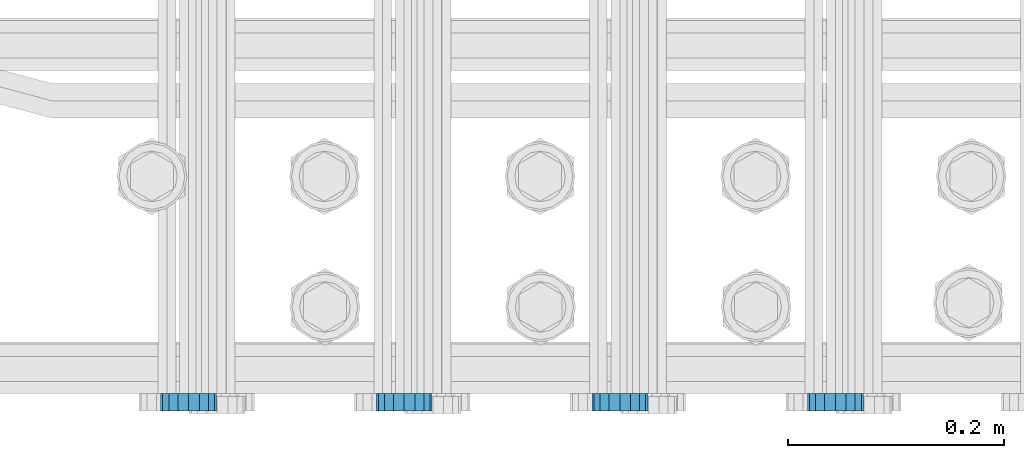
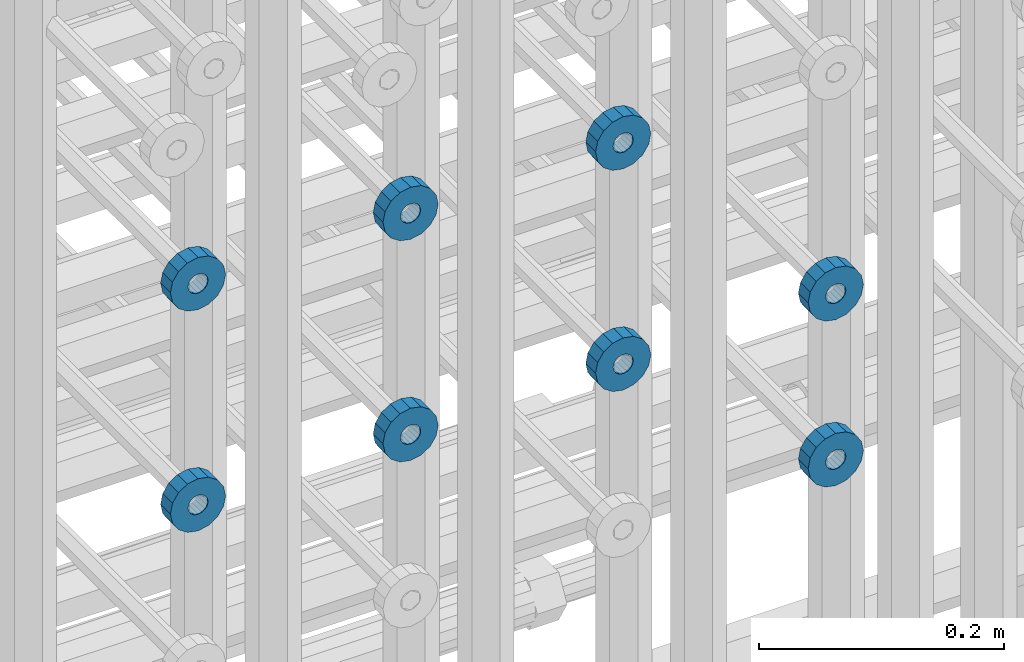
# One storey, part 119 of 177: 8 beams.
"""IFC2X3 building model written with IfcOpenShell, lengths in millimetres."""

from ifc_helpers import new_model, si_unit, frame, origin_with_axes, place, context, subcontext, project, spatial, faceted_brep, material, type_object, element, save


model = new_model("IFC2X3")

# Units and contexts
model_context_1 = context("Model", 3, precision=1e-05, world=origin_with_axes())
model_context_2 = context("Model", 3, precision=1e-05, world=origin_with_axes())
body_context = subcontext(model_context_2, "Body", "Model", "MODEL_VIEW")
ifc_project = project(units=[si_unit("LENGTHUNIT", "METRE", prefix="MILLI"), si_unit("AREAUNIT", "SQUARE_METRE"), si_unit("VOLUMEUNIT", "CUBIC_METRE"), si_unit("MASSUNIT", "GRAM", prefix="KILO"), si_unit("TIMEUNIT", "SECOND"), si_unit("PLANEANGLEUNIT", "RADIAN"), si_unit("SOLIDANGLEUNIT", "STERADIAN"), si_unit("THERMODYNAMICTEMPERATUREUNIT", "DEGREE_CELSIUS"), si_unit("LUMINOUSINTENSITYUNIT", "LUMEN")], contexts=[model_context_1])

# Site, building, storey
site_placement = place(None, origin_with_axes())
site = spatial("IfcSite", under=ifc_project, at=site_placement, CompositionType="ELEMENT")
building_placement = place(site_placement, origin_with_axes())
building = spatial("IfcBuilding", under=site, at=building_placement, Name="Undefined", CompositionType="ELEMENT")
storey_placement = place(building_placement, origin_with_axes())
storey = spatial("IfcBuildingStorey", under=building, at=storey_placement, Name="Undefined", CompositionType="ELEMENT", Elevation=0.0)

# Beams
ifc_material = material(Name="STEEL/Steel_Undefined")
beam_type = type_object("IfcBeamType", PredefinedType="NOTDEFINED")
beam_1_placement = place(storey_placement, frame((2030509.49847313, 6205075.98588034, 20659.9868114202), z_axis=(0.0, 0.0, -1.0), x_axis=(0.0, -1.0, 0.0)))
element("IfcBeam", 1, at=beam_1_placement, inside=storey, type_object=beam_type, material=ifc_material, context=body_context, shape_type="Brep", body=[
    faceted_brep([(0.0, -9.5, 0.0), (0.0, -8.77685555908829, 3.63549260746731), (16.0, -8.77685555908829, 3.63549260746731), (16.0, -9.5, 0.0), (0.0, -6.71751442085952, 6.71751442127061), (16.0, -6.71751442085952, 6.71751442127061), (0.0, -3.63549260701984, 8.77685555885546), (16.0, -3.63549260701984, 8.77685555885546), (-2.02452244836415e-12, 0.0, 9.5), (16.0, 0.0, 9.5), (0.0, 3.63549260701984, 8.77685555885546), (16.0, 3.63549260701984, 8.77685555885546), (0.0, 6.71751442085952, 6.71751442127061), (16.0, 6.71751442085952, 6.71751442127061), (0.0, 8.77685555908829, 3.63549260746731), (16.0, 8.77685555908829, 3.63549260746731), (0.0, 9.5, 0.0), (16.0, 9.5, 0.0), (0.0, 8.77685555908829, -3.63549260746731), (16.0, 8.77685555908829, -3.63549260746731), (0.0, 6.71751442085952, -6.71751442127061), (16.0, 6.71751442085952, -6.71751442127061), (0.0, 3.63549260701984, -8.77685555885546), (16.0, 3.63549260701984, -8.77685555885546), (2.02452244836415e-12, -3.69149155687865e-15, -9.5), (16.0, 0.0, -9.5), (0.0, -3.63549260701984, -8.77685555885546), (16.0, -3.63549260701984, -8.77685555885546), (0.0, -6.71751442085952, -6.71751442127061), (16.0, -6.71751442085952, -6.71751442127061), (0.0, -8.77685555908829, -3.63549260746731), (16.0, -8.77685555908829, -3.63549260746731), (0.0, -26.0, 0.0), (0.0, -24.0208678450435, -9.94976924149159), (16.0, -24.0208678450435, -9.94976924149159), (16.0, -26.0, 0.0), (0.0, -18.3847763109952, -18.3847763108497), (16.0, -18.3847763109952, -18.3847763108497), (0.0, -9.94976924173534, -24.0208678452946), (16.0, -9.94976924173534, -24.0208678452946), (0.0, 0.0, -26.0), (16.0, 0.0, -26.0), (0.0, 9.94976924173534, -24.0208678452946), (16.0, 9.94976924173534, -24.0208678452946), (0.0, 18.3847763109952, -18.3847763108497), (16.0, 18.3847763109952, -18.3847763108497), (0.0, 24.0208678450435, -9.94976924149159), (16.0, 24.0208678450435, -9.94976924149159), (0.0, 26.0, 0.0), (16.0, 26.0, 0.0), (0.0, 24.0208678450435, 9.94976924149159), (16.0, 24.0208678450435, 9.94976924149159), (0.0, 18.3847763109952, 18.3847763108497), (16.0, 18.3847763109952, 18.3847763108497), (0.0, 9.94976924173534, 24.0208678452946), (16.0, 9.94976924173534, 24.0208678452946), (0.0, 0.0, 26.0), (16.0, 0.0, 26.0), (0.0, -9.94976924173534, 24.0208678452946), (16.0, -9.94976924173534, 24.0208678452946), (0.0, -18.3847763109952, 18.3847763108497), (16.0, -18.3847763109952, 18.3847763108497), (0.0, -24.0208678450435, 9.94976924149159), (16.0, -24.0208678450435, 9.94976924149159)], [[[0, 1, 2, 3]], [[1, 4, 5, 2]], [[4, 6, 7, 5]], [[6, 8, 9, 7]], [[8, 10, 11, 9]], [[10, 12, 13, 11]], [[12, 14, 15, 13]], [[14, 16, 17, 15]], [[16, 18, 19, 17]], [[18, 20, 21, 19]], [[20, 22, 23, 21]], [[22, 24, 25, 23]], [[24, 26, 27, 25]], [[26, 28, 29, 27]], [[28, 30, 31, 29]], [[30, 0, 3, 31]], [[32, 33, 34, 35]], [[33, 36, 37, 34]], [[36, 38, 39, 37]], [[38, 40, 41, 39]], [[40, 42, 43, 41]], [[42, 44, 45, 43]], [[44, 46, 47, 45]], [[46, 48, 49, 47]], [[48, 50, 51, 49]], [[50, 52, 53, 51]], [[52, 54, 55, 53]], [[54, 56, 57, 55]], [[56, 58, 59, 57]], [[58, 60, 61, 59]], [[60, 62, 63, 61]], [[62, 32, 35, 63]], [[37, 39, 41, 43, 45, 47, 49, 51, 53, 55, 57, 59, 61, 63, 35, 34], [5, 7, 9, 11, 13, 15, 17, 19, 21, 23, 25, 27, 29, 31, 3, 2]], [[62, 60, 58, 56, 54, 52, 50, 48, 46, 44, 42, 40, 38, 36, 33, 32], [30, 28, 26, 24, 22, 20, 18, 16, 14, 12, 10, 8, 6, 4, 1, 0]]]),
])
beam_2_placement = place(storey_placement, frame((2030309.49847313, 6205075.98588034, 20659.9868114202), z_axis=(0.0, 0.0, -1.0), x_axis=(0.0, -1.0, 0.0)))
element("IfcBeam", 2, at=beam_2_placement, inside=storey, type_object=beam_type, material=ifc_material, context=body_context, shape_type="Brep", body=[
    faceted_brep([(0.0, -9.5, 0.0), (0.0, -8.77685555908829, 3.63549260746731), (16.0, -8.77685555908829, 3.63549260746731), (16.0, -9.5, 0.0), (0.0, -6.71751442085952, 6.71751442127061), (16.0, -6.71751442085952, 6.71751442127061), (0.0, -3.63549260701984, 8.77685555885546), (16.0, -3.63549260701984, 8.77685555885546), (-2.02452244836415e-12, 0.0, 9.5), (16.0, 0.0, 9.5), (0.0, 3.63549260701984, 8.77685555885546), (16.0, 3.63549260701984, 8.77685555885546), (0.0, 6.71751442085952, 6.71751442127061), (16.0, 6.71751442085952, 6.71751442127061), (0.0, 8.77685555908829, 3.63549260746731), (16.0, 8.77685555908829, 3.63549260746731), (0.0, 9.5, 0.0), (16.0, 9.5, 0.0), (0.0, 8.77685555908829, -3.63549260746731), (16.0, 8.77685555908829, -3.63549260746731), (0.0, 6.71751442085952, -6.71751442127061), (16.0, 6.71751442085952, -6.71751442127061), (0.0, 3.63549260701984, -8.77685555885546), (16.0, 3.63549260701984, -8.77685555885546), (2.02452244836415e-12, -3.69149155687865e-15, -9.5), (16.0, 0.0, -9.5), (0.0, -3.63549260701984, -8.77685555885546), (16.0, -3.63549260701984, -8.77685555885546), (0.0, -6.71751442085952, -6.71751442127061), (16.0, -6.71751442085952, -6.71751442127061), (0.0, -8.77685555908829, -3.63549260746731), (16.0, -8.77685555908829, -3.63549260746731), (0.0, -26.0, 0.0), (0.0, -24.0208678450435, -9.94976924149159), (16.0, -24.0208678450435, -9.94976924149159), (16.0, -26.0, 0.0), (0.0, -18.3847763109952, -18.3847763108497), (16.0, -18.3847763109952, -18.3847763108497), (0.0, -9.94976924173534, -24.0208678452946), (16.0, -9.94976924173534, -24.0208678452946), (0.0, 0.0, -26.0), (16.0, 0.0, -26.0), (0.0, 9.94976924173534, -24.0208678452946), (16.0, 9.94976924173534, -24.0208678452946), (0.0, 18.3847763109952, -18.3847763108497), (16.0, 18.3847763109952, -18.3847763108497), (0.0, 24.0208678450435, -9.94976924149159), (16.0, 24.0208678450435, -9.94976924149159), (0.0, 26.0, 0.0), (16.0, 26.0, 0.0), (0.0, 24.0208678450435, 9.94976924149159), (16.0, 24.0208678450435, 9.94976924149159), (0.0, 18.3847763109952, 18.3847763108497), (16.0, 18.3847763109952, 18.3847763108497), (0.0, 9.94976924173534, 24.0208678452946), (16.0, 9.94976924173534, 24.0208678452946), (0.0, 0.0, 26.0), (16.0, 0.0, 26.0), (0.0, -9.94976924173534, 24.0208678452946), (16.0, -9.94976924173534, 24.0208678452946), (0.0, -18.3847763109952, 18.3847763108497), (16.0, -18.3847763109952, 18.3847763108497), (0.0, -24.0208678450435, 9.94976924149159), (16.0, -24.0208678450435, 9.94976924149159)], [[[0, 1, 2, 3]], [[1, 4, 5, 2]], [[4, 6, 7, 5]], [[6, 8, 9, 7]], [[8, 10, 11, 9]], [[10, 12, 13, 11]], [[12, 14, 15, 13]], [[14, 16, 17, 15]], [[16, 18, 19, 17]], [[18, 20, 21, 19]], [[20, 22, 23, 21]], [[22, 24, 25, 23]], [[24, 26, 27, 25]], [[26, 28, 29, 27]], [[28, 30, 31, 29]], [[30, 0, 3, 31]], [[32, 33, 34, 35]], [[33, 36, 37, 34]], [[36, 38, 39, 37]], [[38, 40, 41, 39]], [[40, 42, 43, 41]], [[42, 44, 45, 43]], [[44, 46, 47, 45]], [[46, 48, 49, 47]], [[48, 50, 51, 49]], [[50, 52, 53, 51]], [[52, 54, 55, 53]], [[54, 56, 57, 55]], [[56, 58, 59, 57]], [[58, 60, 61, 59]], [[60, 62, 63, 61]], [[62, 32, 35, 63]], [[37, 39, 41, 43, 45, 47, 49, 51, 53, 55, 57, 59, 61, 63, 35, 34], [5, 7, 9, 11, 13, 15, 17, 19, 21, 23, 25, 27, 29, 31, 3, 2]], [[62, 60, 58, 56, 54, 52, 50, 48, 46, 44, 42, 40, 38, 36, 33, 32], [30, 28, 26, 24, 22, 20, 18, 16, 14, 12, 10, 8, 6, 4, 1, 0]]]),
])
beam_3_placement = place(storey_placement, frame((2030109.49847313, 6205075.98588034, 20659.9868114202), z_axis=(0.0, 0.0, -1.0), x_axis=(0.0, -1.0, 0.0)))
element("IfcBeam", 3, at=beam_3_placement, inside=storey, type_object=beam_type, material=ifc_material, context=body_context, shape_type="Brep", body=[
    faceted_brep([(0.0, -9.5, 0.0), (0.0, -8.77685555908829, 3.63549260746731), (16.0, -8.77685555908829, 3.63549260746731), (16.0, -9.5, 0.0), (0.0, -6.71751442085952, 6.71751442127061), (16.0, -6.71751442085952, 6.71751442127061), (0.0, -3.63549260701984, 8.77685555885546), (16.0, -3.63549260701984, 8.77685555885546), (-2.02452244836415e-12, 0.0, 9.5), (16.0, 0.0, 9.5), (0.0, 3.63549260701984, 8.77685555885546), (16.0, 3.63549260701984, 8.77685555885546), (0.0, 6.71751442085952, 6.71751442127061), (16.0, 6.71751442085952, 6.71751442127061), (0.0, 8.77685555908829, 3.63549260746731), (16.0, 8.77685555908829, 3.63549260746731), (0.0, 9.5, 0.0), (16.0, 9.5, 0.0), (0.0, 8.77685555908829, -3.63549260746731), (16.0, 8.77685555908829, -3.63549260746731), (0.0, 6.71751442085952, -6.71751442127061), (16.0, 6.71751442085952, -6.71751442127061), (0.0, 3.63549260701984, -8.77685555885546), (16.0, 3.63549260701984, -8.77685555885546), (2.02452244836415e-12, -3.69149155687865e-15, -9.5), (16.0, 0.0, -9.5), (0.0, -3.63549260701984, -8.77685555885546), (16.0, -3.63549260701984, -8.77685555885546), (0.0, -6.71751442085952, -6.71751442127061), (16.0, -6.71751442085952, -6.71751442127061), (0.0, -8.77685555908829, -3.63549260746731), (16.0, -8.77685555908829, -3.63549260746731), (0.0, -26.0, 0.0), (0.0, -24.0208678450435, -9.94976924149159), (16.0, -24.0208678450435, -9.94976924149159), (16.0, -26.0, 0.0), (0.0, -18.3847763109952, -18.3847763108497), (16.0, -18.3847763109952, -18.3847763108497), (0.0, -9.94976924173534, -24.0208678452946), (16.0, -9.94976924173534, -24.0208678452946), (0.0, 0.0, -26.0), (16.0, 0.0, -26.0), (0.0, 9.94976924173534, -24.0208678452946), (16.0, 9.94976924173534, -24.0208678452946), (0.0, 18.3847763109952, -18.3847763108497), (16.0, 18.3847763109952, -18.3847763108497), (0.0, 24.0208678450435, -9.94976924149159), (16.0, 24.0208678450435, -9.94976924149159), (0.0, 26.0, 0.0), (16.0, 26.0, 0.0), (0.0, 24.0208678450435, 9.94976924149159), (16.0, 24.0208678450435, 9.94976924149159), (0.0, 18.3847763109952, 18.3847763108497), (16.0, 18.3847763109952, 18.3847763108497), (0.0, 9.94976924173534, 24.0208678452946), (16.0, 9.94976924173534, 24.0208678452946), (0.0, 0.0, 26.0), (16.0, 0.0, 26.0), (0.0, -9.94976924173534, 24.0208678452946), (16.0, -9.94976924173534, 24.0208678452946), (0.0, -18.3847763109952, 18.3847763108497), (16.0, -18.3847763109952, 18.3847763108497), (0.0, -24.0208678450435, 9.94976924149159), (16.0, -24.0208678450435, 9.94976924149159)], [[[0, 1, 2, 3]], [[1, 4, 5, 2]], [[4, 6, 7, 5]], [[6, 8, 9, 7]], [[8, 10, 11, 9]], [[10, 12, 13, 11]], [[12, 14, 15, 13]], [[14, 16, 17, 15]], [[16, 18, 19, 17]], [[18, 20, 21, 19]], [[20, 22, 23, 21]], [[22, 24, 25, 23]], [[24, 26, 27, 25]], [[26, 28, 29, 27]], [[28, 30, 31, 29]], [[30, 0, 3, 31]], [[32, 33, 34, 35]], [[33, 36, 37, 34]], [[36, 38, 39, 37]], [[38, 40, 41, 39]], [[40, 42, 43, 41]], [[42, 44, 45, 43]], [[44, 46, 47, 45]], [[46, 48, 49, 47]], [[48, 50, 51, 49]], [[50, 52, 53, 51]], [[52, 54, 55, 53]], [[54, 56, 57, 55]], [[56, 58, 59, 57]], [[58, 60, 61, 59]], [[60, 62, 63, 61]], [[62, 32, 35, 63]], [[37, 39, 41, 43, 45, 47, 49, 51, 53, 55, 57, 59, 61, 63, 35, 34], [5, 7, 9, 11, 13, 15, 17, 19, 21, 23, 25, 27, 29, 31, 3, 2]], [[62, 60, 58, 56, 54, 52, 50, 48, 46, 44, 42, 40, 38, 36, 33, 32], [30, 28, 26, 24, 22, 20, 18, 16, 14, 12, 10, 8, 6, 4, 1, 0]]]),
])
beam_4_placement = place(storey_placement, frame((2030709.49847313, 6205075.98588033, 20439.9868114202), z_axis=(0.0, 0.0, -1.0), x_axis=(0.0, -1.0, 0.0)))
element("IfcBeam", 4, at=beam_4_placement, inside=storey, type_object=beam_type, material=ifc_material, context=body_context, shape_type="Brep", body=[
    faceted_brep([(0.0, -9.5, 0.0), (0.0, -8.77685555908829, 3.63549260746731), (16.0, -8.77685555908829, 3.63549260746731), (16.0, -9.5, 0.0), (0.0, -6.71751442085952, 6.71751442127061), (16.0, -6.71751442085952, 6.71751442127061), (0.0, -3.63549260701984, 8.77685555885546), (16.0, -3.63549260701984, 8.77685555885546), (-2.02452244836415e-12, 0.0, 9.5), (16.0, 0.0, 9.5), (0.0, 3.63549260701984, 8.77685555885546), (16.0, 3.63549260701984, 8.77685555885546), (0.0, 6.71751442085952, 6.71751442127061), (16.0, 6.71751442085952, 6.71751442127061), (0.0, 8.77685555908829, 3.63549260746731), (16.0, 8.77685555908829, 3.63549260746731), (0.0, 9.5, 0.0), (16.0, 9.5, 0.0), (0.0, 8.77685555908829, -3.63549260746731), (16.0, 8.77685555908829, -3.63549260746731), (0.0, 6.71751442085952, -6.71751442127061), (16.0, 6.71751442085952, -6.71751442127061), (0.0, 3.63549260701984, -8.77685555885546), (16.0, 3.63549260701984, -8.77685555885546), (2.02452244836415e-12, -3.69149155687865e-15, -9.5), (16.0, 0.0, -9.5), (0.0, -3.63549260701984, -8.77685555885546), (16.0, -3.63549260701984, -8.77685555885546), (0.0, -6.71751442085952, -6.71751442127061), (16.0, -6.71751442085952, -6.71751442127061), (0.0, -8.77685555908829, -3.63549260746731), (16.0, -8.77685555908829, -3.63549260746731), (0.0, -26.0, 0.0), (0.0, -24.0208678450435, -9.94976924149159), (16.0, -24.0208678450435, -9.94976924149159), (16.0, -26.0, 0.0), (0.0, -18.3847763109952, -18.3847763108497), (16.0, -18.3847763109952, -18.3847763108497), (0.0, -9.94976924173534, -24.0208678452946), (16.0, -9.94976924173534, -24.0208678452946), (0.0, 0.0, -26.0), (16.0, 0.0, -26.0), (0.0, 9.94976924173534, -24.0208678452946), (16.0, 9.94976924173534, -24.0208678452946), (0.0, 18.3847763109952, -18.3847763108497), (16.0, 18.3847763109952, -18.3847763108497), (0.0, 24.0208678450435, -9.94976924149159), (16.0, 24.0208678450435, -9.94976924149159), (0.0, 26.0, 0.0), (16.0, 26.0, 0.0), (0.0, 24.0208678450435, 9.94976924149159), (16.0, 24.0208678450435, 9.94976924149159), (0.0, 18.3847763109952, 18.3847763108497), (16.0, 18.3847763109952, 18.3847763108497), (0.0, 9.94976924173534, 24.0208678452946), (16.0, 9.94976924173534, 24.0208678452946), (0.0, 0.0, 26.0), (16.0, 0.0, 26.0), (0.0, -9.94976924173534, 24.0208678452946), (16.0, -9.94976924173534, 24.0208678452946), (0.0, -18.3847763109952, 18.3847763108497), (16.0, -18.3847763109952, 18.3847763108497), (0.0, -24.0208678450435, 9.94976924149159), (16.0, -24.0208678450435, 9.94976924149159)], [[[0, 1, 2, 3]], [[1, 4, 5, 2]], [[4, 6, 7, 5]], [[6, 8, 9, 7]], [[8, 10, 11, 9]], [[10, 12, 13, 11]], [[12, 14, 15, 13]], [[14, 16, 17, 15]], [[16, 18, 19, 17]], [[18, 20, 21, 19]], [[20, 22, 23, 21]], [[22, 24, 25, 23]], [[24, 26, 27, 25]], [[26, 28, 29, 27]], [[28, 30, 31, 29]], [[30, 0, 3, 31]], [[32, 33, 34, 35]], [[33, 36, 37, 34]], [[36, 38, 39, 37]], [[38, 40, 41, 39]], [[40, 42, 43, 41]], [[42, 44, 45, 43]], [[44, 46, 47, 45]], [[46, 48, 49, 47]], [[48, 50, 51, 49]], [[50, 52, 53, 51]], [[52, 54, 55, 53]], [[54, 56, 57, 55]], [[56, 58, 59, 57]], [[58, 60, 61, 59]], [[60, 62, 63, 61]], [[62, 32, 35, 63]], [[37, 39, 41, 43, 45, 47, 49, 51, 53, 55, 57, 59, 61, 63, 35, 34], [5, 7, 9, 11, 13, 15, 17, 19, 21, 23, 25, 27, 29, 31, 3, 2]], [[62, 60, 58, 56, 54, 52, 50, 48, 46, 44, 42, 40, 38, 36, 33, 32], [30, 28, 26, 24, 22, 20, 18, 16, 14, 12, 10, 8, 6, 4, 1, 0]]]),
])
beam_5_placement = place(storey_placement, frame((2030509.49847313, 6205075.98588033, 20439.9868114202), z_axis=(0.0, 0.0, -1.0), x_axis=(0.0, -1.0, 0.0)))
element("IfcBeam", 5, at=beam_5_placement, inside=storey, type_object=beam_type, material=ifc_material, context=body_context, shape_type="Brep", body=[
    faceted_brep([(0.0, -9.5, 0.0), (0.0, -8.77685555908829, 3.63549260746731), (16.0, -8.77685555908829, 3.63549260746731), (16.0, -9.5, 0.0), (0.0, -6.71751442085952, 6.71751442127061), (16.0, -6.71751442085952, 6.71751442127061), (0.0, -3.63549260701984, 8.77685555885546), (16.0, -3.63549260701984, 8.77685555885546), (-2.02452244836415e-12, 0.0, 9.5), (16.0, 0.0, 9.5), (0.0, 3.63549260701984, 8.77685555885546), (16.0, 3.63549260701984, 8.77685555885546), (0.0, 6.71751442085952, 6.71751442127061), (16.0, 6.71751442085952, 6.71751442127061), (0.0, 8.77685555908829, 3.63549260746731), (16.0, 8.77685555908829, 3.63549260746731), (0.0, 9.5, 0.0), (16.0, 9.5, 0.0), (0.0, 8.77685555908829, -3.63549260746731), (16.0, 8.77685555908829, -3.63549260746731), (0.0, 6.71751442085952, -6.71751442127061), (16.0, 6.71751442085952, -6.71751442127061), (0.0, 3.63549260701984, -8.77685555885546), (16.0, 3.63549260701984, -8.77685555885546), (2.02452244836415e-12, -3.69149155687865e-15, -9.5), (16.0, 0.0, -9.5), (0.0, -3.63549260701984, -8.77685555885546), (16.0, -3.63549260701984, -8.77685555885546), (0.0, -6.71751442085952, -6.71751442127061), (16.0, -6.71751442085952, -6.71751442127061), (0.0, -8.77685555908829, -3.63549260746731), (16.0, -8.77685555908829, -3.63549260746731), (0.0, -26.0, 0.0), (0.0, -24.0208678450435, -9.94976924149159), (16.0, -24.0208678450435, -9.94976924149159), (16.0, -26.0, 0.0), (0.0, -18.3847763109952, -18.3847763108497), (16.0, -18.3847763109952, -18.3847763108497), (0.0, -9.94976924173534, -24.0208678452946), (16.0, -9.94976924173534, -24.0208678452946), (0.0, 0.0, -26.0), (16.0, 0.0, -26.0), (0.0, 9.94976924173534, -24.0208678452946), (16.0, 9.94976924173534, -24.0208678452946), (0.0, 18.3847763109952, -18.3847763108497), (16.0, 18.3847763109952, -18.3847763108497), (0.0, 24.0208678450435, -9.94976924149159), (16.0, 24.0208678450435, -9.94976924149159), (0.0, 26.0, 0.0), (16.0, 26.0, 0.0), (0.0, 24.0208678450435, 9.94976924149159), (16.0, 24.0208678450435, 9.94976924149159), (0.0, 18.3847763109952, 18.3847763108497), (16.0, 18.3847763109952, 18.3847763108497), (0.0, 9.94976924173534, 24.0208678452946), (16.0, 9.94976924173534, 24.0208678452946), (0.0, 0.0, 26.0), (16.0, 0.0, 26.0), (0.0, -9.94976924173534, 24.0208678452946), (16.0, -9.94976924173534, 24.0208678452946), (0.0, -18.3847763109952, 18.3847763108497), (16.0, -18.3847763109952, 18.3847763108497), (0.0, -24.0208678450435, 9.94976924149159), (16.0, -24.0208678450435, 9.94976924149159)], [[[0, 1, 2, 3]], [[1, 4, 5, 2]], [[4, 6, 7, 5]], [[6, 8, 9, 7]], [[8, 10, 11, 9]], [[10, 12, 13, 11]], [[12, 14, 15, 13]], [[14, 16, 17, 15]], [[16, 18, 19, 17]], [[18, 20, 21, 19]], [[20, 22, 23, 21]], [[22, 24, 25, 23]], [[24, 26, 27, 25]], [[26, 28, 29, 27]], [[28, 30, 31, 29]], [[30, 0, 3, 31]], [[32, 33, 34, 35]], [[33, 36, 37, 34]], [[36, 38, 39, 37]], [[38, 40, 41, 39]], [[40, 42, 43, 41]], [[42, 44, 45, 43]], [[44, 46, 47, 45]], [[46, 48, 49, 47]], [[48, 50, 51, 49]], [[50, 52, 53, 51]], [[52, 54, 55, 53]], [[54, 56, 57, 55]], [[56, 58, 59, 57]], [[58, 60, 61, 59]], [[60, 62, 63, 61]], [[62, 32, 35, 63]], [[37, 39, 41, 43, 45, 47, 49, 51, 53, 55, 57, 59, 61, 63, 35, 34], [5, 7, 9, 11, 13, 15, 17, 19, 21, 23, 25, 27, 29, 31, 3, 2]], [[62, 60, 58, 56, 54, 52, 50, 48, 46, 44, 42, 40, 38, 36, 33, 32], [30, 28, 26, 24, 22, 20, 18, 16, 14, 12, 10, 8, 6, 4, 1, 0]]]),
])
beam_6_placement = place(storey_placement, frame((2030309.49847313, 6205075.98588033, 20439.9868114202), z_axis=(0.0, 0.0, -1.0), x_axis=(0.0, -1.0, 0.0)))
element("IfcBeam", 6, at=beam_6_placement, inside=storey, type_object=beam_type, material=ifc_material, context=body_context, shape_type="Brep", body=[
    faceted_brep([(0.0, -9.5, 0.0), (0.0, -8.77685555908829, 3.63549260746731), (16.0, -8.77685555908829, 3.63549260746731), (16.0, -9.5, 0.0), (0.0, -6.71751442085952, 6.71751442127061), (16.0, -6.71751442085952, 6.71751442127061), (0.0, -3.63549260701984, 8.77685555885546), (16.0, -3.63549260701984, 8.77685555885546), (-2.02452244836415e-12, 0.0, 9.5), (16.0, 0.0, 9.5), (0.0, 3.63549260701984, 8.77685555885546), (16.0, 3.63549260701984, 8.77685555885546), (0.0, 6.71751442085952, 6.71751442127061), (16.0, 6.71751442085952, 6.71751442127061), (0.0, 8.77685555908829, 3.63549260746731), (16.0, 8.77685555908829, 3.63549260746731), (0.0, 9.5, 0.0), (16.0, 9.5, 0.0), (0.0, 8.77685555908829, -3.63549260746731), (16.0, 8.77685555908829, -3.63549260746731), (0.0, 6.71751442085952, -6.71751442127061), (16.0, 6.71751442085952, -6.71751442127061), (0.0, 3.63549260701984, -8.77685555885546), (16.0, 3.63549260701984, -8.77685555885546), (2.02452244836415e-12, -3.69149155687865e-15, -9.5), (16.0, 0.0, -9.5), (0.0, -3.63549260701984, -8.77685555885546), (16.0, -3.63549260701984, -8.77685555885546), (0.0, -6.71751442085952, -6.71751442127061), (16.0, -6.71751442085952, -6.71751442127061), (0.0, -8.77685555908829, -3.63549260746731), (16.0, -8.77685555908829, -3.63549260746731), (0.0, -26.0, 0.0), (0.0, -24.0208678450435, -9.94976924149159), (16.0, -24.0208678450435, -9.94976924149159), (16.0, -26.0, 0.0), (0.0, -18.3847763109952, -18.3847763108497), (16.0, -18.3847763109952, -18.3847763108497), (0.0, -9.94976924173534, -24.0208678452946), (16.0, -9.94976924173534, -24.0208678452946), (0.0, 0.0, -26.0), (16.0, 0.0, -26.0), (0.0, 9.94976924173534, -24.0208678452946), (16.0, 9.94976924173534, -24.0208678452946), (0.0, 18.3847763109952, -18.3847763108497), (16.0, 18.3847763109952, -18.3847763108497), (0.0, 24.0208678450435, -9.94976924149159), (16.0, 24.0208678450435, -9.94976924149159), (0.0, 26.0, 0.0), (16.0, 26.0, 0.0), (0.0, 24.0208678450435, 9.94976924149159), (16.0, 24.0208678450435, 9.94976924149159), (0.0, 18.3847763109952, 18.3847763108497), (16.0, 18.3847763109952, 18.3847763108497), (0.0, 9.94976924173534, 24.0208678452946), (16.0, 9.94976924173534, 24.0208678452946), (0.0, 0.0, 26.0), (16.0, 0.0, 26.0), (0.0, -9.94976924173534, 24.0208678452946), (16.0, -9.94976924173534, 24.0208678452946), (0.0, -18.3847763109952, 18.3847763108497), (16.0, -18.3847763109952, 18.3847763108497), (0.0, -24.0208678450435, 9.94976924149159), (16.0, -24.0208678450435, 9.94976924149159)], [[[0, 1, 2, 3]], [[1, 4, 5, 2]], [[4, 6, 7, 5]], [[6, 8, 9, 7]], [[8, 10, 11, 9]], [[10, 12, 13, 11]], [[12, 14, 15, 13]], [[14, 16, 17, 15]], [[16, 18, 19, 17]], [[18, 20, 21, 19]], [[20, 22, 23, 21]], [[22, 24, 25, 23]], [[24, 26, 27, 25]], [[26, 28, 29, 27]], [[28, 30, 31, 29]], [[30, 0, 3, 31]], [[32, 33, 34, 35]], [[33, 36, 37, 34]], [[36, 38, 39, 37]], [[38, 40, 41, 39]], [[40, 42, 43, 41]], [[42, 44, 45, 43]], [[44, 46, 47, 45]], [[46, 48, 49, 47]], [[48, 50, 51, 49]], [[50, 52, 53, 51]], [[52, 54, 55, 53]], [[54, 56, 57, 55]], [[56, 58, 59, 57]], [[58, 60, 61, 59]], [[60, 62, 63, 61]], [[62, 32, 35, 63]], [[37, 39, 41, 43, 45, 47, 49, 51, 53, 55, 57, 59, 61, 63, 35, 34], [5, 7, 9, 11, 13, 15, 17, 19, 21, 23, 25, 27, 29, 31, 3, 2]], [[62, 60, 58, 56, 54, 52, 50, 48, 46, 44, 42, 40, 38, 36, 33, 32], [30, 28, 26, 24, 22, 20, 18, 16, 14, 12, 10, 8, 6, 4, 1, 0]]]),
])
beam_7_placement = place(storey_placement, frame((2030109.49847313, 6205075.98588033, 20439.9868114202), z_axis=(0.0, 0.0, -1.0), x_axis=(0.0, -1.0, 0.0)))
element("IfcBeam", 7, at=beam_7_placement, inside=storey, type_object=beam_type, material=ifc_material, context=body_context, shape_type="Brep", body=[
    faceted_brep([(0.0, -9.5, 0.0), (0.0, -8.77685555908829, 3.63549260746731), (16.0, -8.77685555908829, 3.63549260746731), (16.0, -9.5, 0.0), (0.0, -6.71751442085952, 6.71751442127061), (16.0, -6.71751442085952, 6.71751442127061), (0.0, -3.63549260701984, 8.77685555885546), (16.0, -3.63549260701984, 8.77685555885546), (-2.02452244836415e-12, 0.0, 9.5), (16.0, 0.0, 9.5), (0.0, 3.63549260701984, 8.77685555885546), (16.0, 3.63549260701984, 8.77685555885546), (0.0, 6.71751442085952, 6.71751442127061), (16.0, 6.71751442085952, 6.71751442127061), (0.0, 8.77685555908829, 3.63549260746731), (16.0, 8.77685555908829, 3.63549260746731), (0.0, 9.5, 0.0), (16.0, 9.5, 0.0), (0.0, 8.77685555908829, -3.63549260746731), (16.0, 8.77685555908829, -3.63549260746731), (0.0, 6.71751442085952, -6.71751442127061), (16.0, 6.71751442085952, -6.71751442127061), (0.0, 3.63549260701984, -8.77685555885546), (16.0, 3.63549260701984, -8.77685555885546), (2.02452244836415e-12, -3.69149155687865e-15, -9.5), (16.0, 0.0, -9.5), (0.0, -3.63549260701984, -8.77685555885546), (16.0, -3.63549260701984, -8.77685555885546), (0.0, -6.71751442085952, -6.71751442127061), (16.0, -6.71751442085952, -6.71751442127061), (0.0, -8.77685555908829, -3.63549260746731), (16.0, -8.77685555908829, -3.63549260746731), (0.0, -26.0, 0.0), (0.0, -24.0208678450435, -9.94976924149159), (16.0, -24.0208678450435, -9.94976924149159), (16.0, -26.0, 0.0), (0.0, -18.3847763109952, -18.3847763108497), (16.0, -18.3847763109952, -18.3847763108497), (0.0, -9.94976924173534, -24.0208678452946), (16.0, -9.94976924173534, -24.0208678452946), (0.0, 0.0, -26.0), (16.0, 0.0, -26.0), (0.0, 9.94976924173534, -24.0208678452946), (16.0, 9.94976924173534, -24.0208678452946), (0.0, 18.3847763109952, -18.3847763108497), (16.0, 18.3847763109952, -18.3847763108497), (0.0, 24.0208678450435, -9.94976924149159), (16.0, 24.0208678450435, -9.94976924149159), (0.0, 26.0, 0.0), (16.0, 26.0, 0.0), (0.0, 24.0208678450435, 9.94976924149159), (16.0, 24.0208678450435, 9.94976924149159), (0.0, 18.3847763109952, 18.3847763108497), (16.0, 18.3847763109952, 18.3847763108497), (0.0, 9.94976924173534, 24.0208678452946), (16.0, 9.94976924173534, 24.0208678452946), (0.0, 0.0, 26.0), (16.0, 0.0, 26.0), (0.0, -9.94976924173534, 24.0208678452946), (16.0, -9.94976924173534, 24.0208678452946), (0.0, -18.3847763109952, 18.3847763108497), (16.0, -18.3847763109952, 18.3847763108497), (0.0, -24.0208678450435, 9.94976924149159), (16.0, -24.0208678450435, 9.94976924149159)], [[[0, 1, 2, 3]], [[1, 4, 5, 2]], [[4, 6, 7, 5]], [[6, 8, 9, 7]], [[8, 10, 11, 9]], [[10, 12, 13, 11]], [[12, 14, 15, 13]], [[14, 16, 17, 15]], [[16, 18, 19, 17]], [[18, 20, 21, 19]], [[20, 22, 23, 21]], [[22, 24, 25, 23]], [[24, 26, 27, 25]], [[26, 28, 29, 27]], [[28, 30, 31, 29]], [[30, 0, 3, 31]], [[32, 33, 34, 35]], [[33, 36, 37, 34]], [[36, 38, 39, 37]], [[38, 40, 41, 39]], [[40, 42, 43, 41]], [[42, 44, 45, 43]], [[44, 46, 47, 45]], [[46, 48, 49, 47]], [[48, 50, 51, 49]], [[50, 52, 53, 51]], [[52, 54, 55, 53]], [[54, 56, 57, 55]], [[56, 58, 59, 57]], [[58, 60, 61, 59]], [[60, 62, 63, 61]], [[62, 32, 35, 63]], [[37, 39, 41, 43, 45, 47, 49, 51, 53, 55, 57, 59, 61, 63, 35, 34], [5, 7, 9, 11, 13, 15, 17, 19, 21, 23, 25, 27, 29, 31, 3, 2]], [[62, 60, 58, 56, 54, 52, 50, 48, 46, 44, 42, 40, 38, 36, 33, 32], [30, 28, 26, 24, 22, 20, 18, 16, 14, 12, 10, 8, 6, 4, 1, 0]]]),
])
beam_8_placement = place(storey_placement, frame((2030709.49847313, 6205075.98588034, 20274.9868114202), z_axis=(0.0, 0.0, -1.0), x_axis=(0.0, -1.0, 0.0)))
element("IfcBeam", 8, at=beam_8_placement, inside=storey, type_object=beam_type, material=ifc_material, context=body_context, shape_type="Brep", body=[
    faceted_brep([(0.0, -9.5, 0.0), (0.0, -8.77685555908829, 3.63549260746731), (16.0, -8.77685555908829, 3.63549260746731), (16.0, -9.5, 0.0), (0.0, -6.71751442085952, 6.71751442127061), (16.0, -6.71751442085952, 6.71751442127061), (0.0, -3.63549260701984, 8.77685555885546), (16.0, -3.63549260701984, 8.77685555885546), (-2.02452244836415e-12, 0.0, 9.5), (16.0, 0.0, 9.5), (0.0, 3.63549260701984, 8.77685555885546), (16.0, 3.63549260701984, 8.77685555885546), (0.0, 6.71751442085952, 6.71751442127061), (16.0, 6.71751442085952, 6.71751442127061), (0.0, 8.77685555908829, 3.63549260746731), (16.0, 8.77685555908829, 3.63549260746731), (0.0, 9.5, 0.0), (16.0, 9.5, 0.0), (0.0, 8.77685555908829, -3.63549260746731), (16.0, 8.77685555908829, -3.63549260746731), (0.0, 6.71751442085952, -6.71751442127061), (16.0, 6.71751442085952, -6.71751442127061), (0.0, 3.63549260701984, -8.77685555885546), (16.0, 3.63549260701984, -8.77685555885546), (2.02452244836415e-12, -3.69149155687865e-15, -9.5), (16.0, 0.0, -9.5), (0.0, -3.63549260701984, -8.77685555885546), (16.0, -3.63549260701984, -8.77685555885546), (0.0, -6.71751442085952, -6.71751442127061), (16.0, -6.71751442085952, -6.71751442127061), (0.0, -8.77685555908829, -3.63549260746731), (16.0, -8.77685555908829, -3.63549260746731), (0.0, -26.0, 0.0), (0.0, -24.0208678450435, -9.94976924149159), (16.0, -24.0208678450435, -9.94976924149159), (16.0, -26.0, 0.0), (0.0, -18.3847763109952, -18.3847763108497), (16.0, -18.3847763109952, -18.3847763108497), (0.0, -9.94976924173534, -24.0208678452946), (16.0, -9.94976924173534, -24.0208678452946), (0.0, 0.0, -26.0), (16.0, 0.0, -26.0), (0.0, 9.94976924173534, -24.0208678452946), (16.0, 9.94976924173534, -24.0208678452946), (0.0, 18.3847763109952, -18.3847763108497), (16.0, 18.3847763109952, -18.3847763108497), (0.0, 24.0208678450435, -9.94976924149159), (16.0, 24.0208678450435, -9.94976924149159), (0.0, 26.0, 0.0), (16.0, 26.0, 0.0), (0.0, 24.0208678450435, 9.94976924149159), (16.0, 24.0208678450435, 9.94976924149159), (0.0, 18.3847763109952, 18.3847763108497), (16.0, 18.3847763109952, 18.3847763108497), (0.0, 9.94976924173534, 24.0208678452946), (16.0, 9.94976924173534, 24.0208678452946), (0.0, 0.0, 26.0), (16.0, 0.0, 26.0), (0.0, -9.94976924173534, 24.0208678452946), (16.0, -9.94976924173534, 24.0208678452946), (0.0, -18.3847763109952, 18.3847763108497), (16.0, -18.3847763109952, 18.3847763108497), (0.0, -24.0208678450435, 9.94976924149159), (16.0, -24.0208678450435, 9.94976924149159)], [[[0, 1, 2, 3]], [[1, 4, 5, 2]], [[4, 6, 7, 5]], [[6, 8, 9, 7]], [[8, 10, 11, 9]], [[10, 12, 13, 11]], [[12, 14, 15, 13]], [[14, 16, 17, 15]], [[16, 18, 19, 17]], [[18, 20, 21, 19]], [[20, 22, 23, 21]], [[22, 24, 25, 23]], [[24, 26, 27, 25]], [[26, 28, 29, 27]], [[28, 30, 31, 29]], [[30, 0, 3, 31]], [[32, 33, 34, 35]], [[33, 36, 37, 34]], [[36, 38, 39, 37]], [[38, 40, 41, 39]], [[40, 42, 43, 41]], [[42, 44, 45, 43]], [[44, 46, 47, 45]], [[46, 48, 49, 47]], [[48, 50, 51, 49]], [[50, 52, 53, 51]], [[52, 54, 55, 53]], [[54, 56, 57, 55]], [[56, 58, 59, 57]], [[58, 60, 61, 59]], [[60, 62, 63, 61]], [[62, 32, 35, 63]], [[37, 39, 41, 43, 45, 47, 49, 51, 53, 55, 57, 59, 61, 63, 35, 34], [5, 7, 9, 11, 13, 15, 17, 19, 21, 23, 25, 27, 29, 31, 3, 2]], [[62, 60, 58, 56, 54, 52, 50, 48, 46, 44, 42, 40, 38, 36, 33, 32], [30, 28, 26, 24, 22, 20, 18, 16, 14, 12, 10, 8, 6, 4, 1, 0]]]),
])

save(model, "model.ifc")
